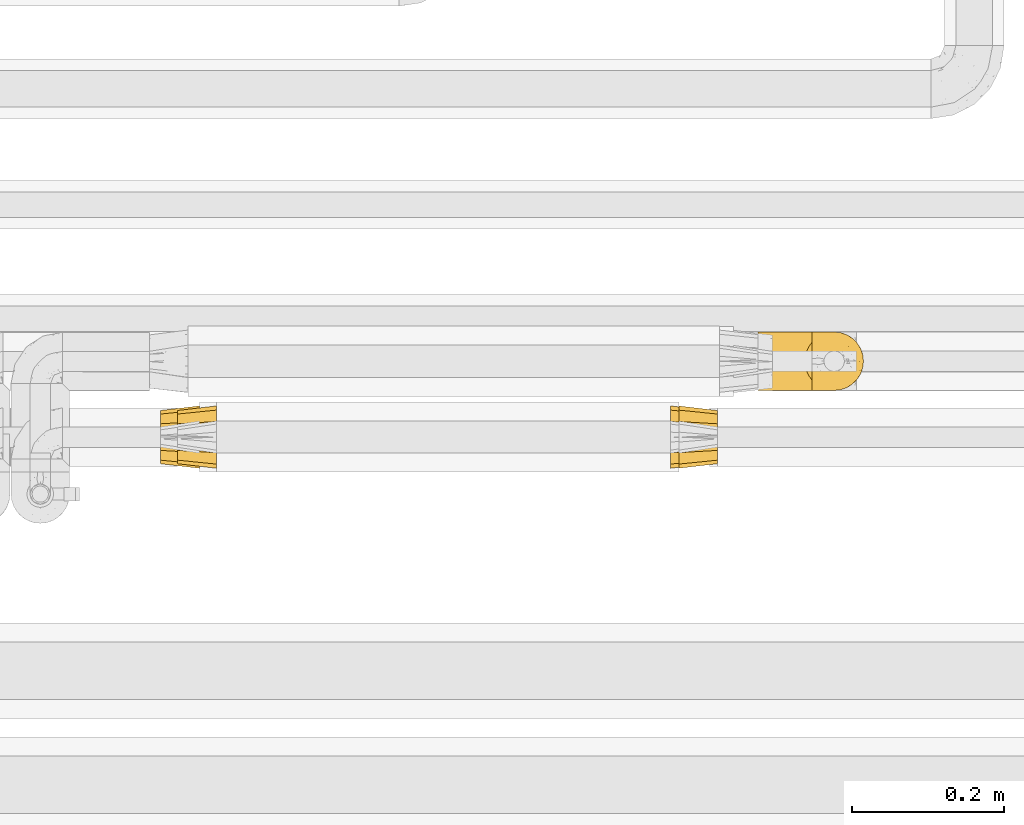
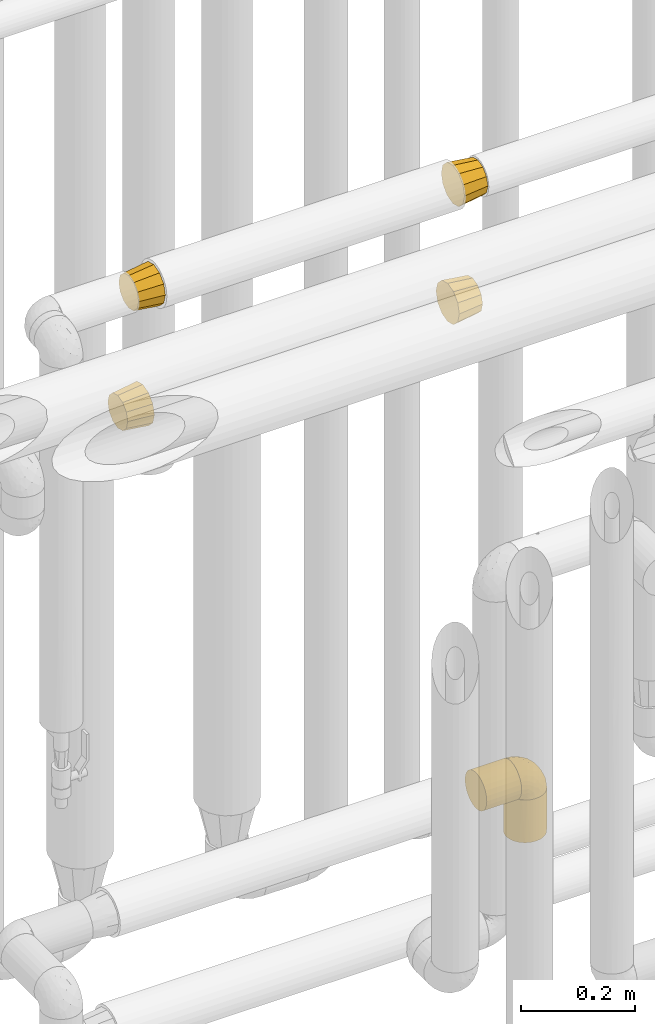
# One storey, part 471 of 827: 7 coverings.
"""IFC2X3 building model written with IfcOpenShell, lengths in millimetres."""

from ifc_helpers import new_model, entity, si_unit, converted_unit, derived_unit, direction, frame, origin, place, context, subcontext, project, spatial, faceted_brep, element, save


model = new_model("IFC2X3")

# Units and contexts
model_context = context("Model", 3, precision=0.01, world=origin(), true_north=direction((6.12303176911189e-17, 1.0)))
body_context = subcontext(model_context, "Body", "Model", "MODEL_VIEW")
ifc_project = project(units=[si_unit("LENGTHUNIT", "METRE", prefix="MILLI"), si_unit("AREAUNIT", "SQUARE_METRE"), si_unit("VOLUMEUNIT", "CUBIC_METRE"), converted_unit("PLANEANGLEUNIT", "DEGREE", entity("IfcRatioMeasure", 0.0174532925199433), si_unit("PLANEANGLEUNIT", "RADIAN"), dimensions=[0, 0, 0, 0, 0, 0, 0]), si_unit("MASSUNIT", "GRAM", prefix="KILO"), derived_unit("MASSDENSITYUNIT", [(si_unit("MASSUNIT", "GRAM", prefix="KILO"), 1), (si_unit("LENGTHUNIT", "METRE"), -3)]), derived_unit("MOMENTOFINERTIAUNIT", [(si_unit("LENGTHUNIT", "METRE"), 4)]), si_unit("TIMEUNIT", "SECOND"), si_unit("FREQUENCYUNIT", "HERTZ"), si_unit("THERMODYNAMICTEMPERATUREUNIT", "DEGREE_CELSIUS"), derived_unit("THERMALTRANSMITTANCEUNIT", [(si_unit("MASSUNIT", "GRAM", prefix="KILO"), 1), (si_unit("THERMODYNAMICTEMPERATUREUNIT", "KELVIN"), -1), (si_unit("TIMEUNIT", "SECOND"), -3)]), derived_unit("VOLUMETRICFLOWRATEUNIT", [(si_unit("LENGTHUNIT", "METRE"), 3), (si_unit("TIMEUNIT", "SECOND"), -1)]), derived_unit("MASSFLOWRATEUNIT", [(si_unit("MASSUNIT", "GRAM", prefix="KILO"), 1), (si_unit("TIMEUNIT", "SECOND"), -1)]), derived_unit("ROTATIONALFREQUENCYUNIT", [(si_unit("TIMEUNIT", "SECOND"), -1)]), si_unit("ELECTRICCURRENTUNIT", "AMPERE"), si_unit("ELECTRICVOLTAGEUNIT", "VOLT"), si_unit("POWERUNIT", "WATT"), si_unit("FORCEUNIT", "NEWTON", prefix="KILO"), si_unit("ILLUMINANCEUNIT", "LUX"), si_unit("LUMINOUSFLUXUNIT", "LUMEN"), si_unit("LUMINOUSINTENSITYUNIT", "CANDELA"), derived_unit("USERDEFINED", [(si_unit("MASSUNIT", "GRAM", prefix="KILO"), -1), (si_unit("LENGTHUNIT", "METRE"), -2), (si_unit("TIMEUNIT", "SECOND"), 3), (si_unit("LUMINOUSFLUXUNIT", "LUMEN"), 1)]), derived_unit("LINEARVELOCITYUNIT", [(si_unit("LENGTHUNIT", "METRE"), 1), (si_unit("TIMEUNIT", "SECOND"), -1)]), si_unit("PRESSUREUNIT", "PASCAL"), derived_unit("USERDEFINED", [(si_unit("LENGTHUNIT", "METRE"), -2), (si_unit("MASSUNIT", "GRAM", prefix="KILO"), 1), (si_unit("TIMEUNIT", "SECOND"), -2)]), derived_unit("LINEARFORCEUNIT", [(si_unit("MASSUNIT", "GRAM", prefix="KILO"), 1), (si_unit("LENGTHUNIT", "METRE"), 1), (si_unit("TIMEUNIT", "SECOND"), -2), (si_unit("LENGTHUNIT", "METRE"), -1)]), derived_unit("PLANARFORCEUNIT", [(si_unit("MASSUNIT", "GRAM", prefix="KILO"), 1), (si_unit("LENGTHUNIT", "METRE"), 1), (si_unit("TIMEUNIT", "SECOND"), -2), (si_unit("LENGTHUNIT", "METRE"), -2)])], contexts=[model_context])

# Site, building, storey
site_placement = place(None, origin())
site = spatial("IfcSite", under=ifc_project, at=site_placement, CompositionType="ELEMENT")
building_placement = place(site_placement, origin())
building = spatial("IfcBuilding", under=site, at=building_placement, CompositionType="ELEMENT")
storey_placement = place(building_placement, frame((0.0, 0.0, 28200.0)))
storey = spatial("IfcBuildingStorey", under=building, at=storey_placement, Name="08", CompositionType="ELEMENT", Elevation=28200.0)

# Coverings
covering_1_placement = place(storey_placement, frame((58750.1, 16337.24, 2607.4)))
element("IfcCovering", 1, at=covering_1_placement, inside=storey, Name=":ADSK_", ObjectType=":ADSK_", PredefinedType="INSULATION", context=body_context, shape_type="Brep", body=[
    faceted_brep([(51.0, 14.59, 70.6), (51.0, 7.09, 63.1), (51.0, 5.43, 56.92), (51.0, 3.51, 49.76), (51.0, 1.6, 42.6), (51.0, 3.51, 35.43), (51.0, 5.43, 28.27), (51.0, 7.09, 22.1), (51.0, 14.59, 14.59), (51.0, 22.1, 7.09), (51.0, 28.27, 5.43), (51.0, 35.43, 3.51), (51.0, 42.6, 1.6), (51.0, 49.76, 3.51), (51.0, 56.92, 5.43), (51.0, 63.1, 7.09), (51.0, 70.6, 14.59), (51.0, 78.1, 22.1), (51.0, 79.76, 28.27), (51.0, 81.68, 35.43), (51.0, 83.6, 42.6), (51.0, 81.68, 49.76), (51.0, 79.76, 56.92), (51.0, 78.1, 63.1), (51.0, 70.6, 70.6), (51.0, 63.1, 78.1), (51.0, 56.92, 79.76), (51.0, 49.76, 81.68), (51.0, 42.6, 83.6), (51.0, 35.43, 81.68), (51.0, 28.27, 79.76), (51.0, 22.1, 78.1), (0.0, 60.1, 72.91), (0.0, 66.5, 66.5), (0.0, 72.91, 60.1), (0.0, 75.25, 51.35), (0.0, 77.6, 42.6), (0.0, 75.25, 33.85), (0.0, 72.91, 25.1), (0.0, 66.5, 18.69), (0.0, 60.1, 12.28), (0.0, 51.35, 9.94), (0.0, 42.6, 7.6), (0.0, 33.85, 9.94), (0.0, 25.1, 12.28), (0.0, 18.69, 18.69), (0.0, 12.28, 25.1), (0.0, 9.94, 33.85), (0.0, 7.6, 42.6), (0.0, 9.94, 51.35), (0.0, 12.28, 60.1), (0.0, 18.69, 66.5), (0.0, 25.1, 72.91), (0.0, 33.85, 75.25), (0.0, 42.6, 77.6), (0.0, 51.35, 75.25)], [[[0, 1, 2, 3, 4, 5, 6, 7, 8, 9, 10, 11, 12, 13, 14, 15, 16, 17, 18, 19, 20, 21, 22, 23, 24, 25, 26, 27, 28, 29, 30, 31]], [[32, 33, 34, 35, 36, 37, 38, 39, 40, 41, 42, 43, 44, 45, 46, 47, 48, 49, 50, 51, 52, 53, 54, 55]], [[46, 7, 6, 5, 4, 48, 47]], [[8, 7, 46, 45, 44, 9]], [[11, 10, 9, 44, 43, 42, 12]], [[40, 15, 14, 13, 12, 42, 41]], [[16, 15, 40, 39, 38, 17]], [[19, 18, 17, 38, 37, 36, 20]], [[34, 23, 22, 21, 20, 36, 35]], [[24, 23, 34, 33, 32, 25]], [[27, 26, 25, 32, 55, 54, 28]], [[52, 31, 30, 29, 28, 54, 53]], [[0, 31, 52, 51, 50, 1]], [[3, 2, 1, 50, 49, 48, 4]]]),
])
covering_2_placement = place(storey_placement, frame((59409.44, 16337.24, 2607.4)))
element("IfcCovering", 2, at=covering_2_placement, inside=storey, Name=":ADSK_", ObjectType=":ADSK_", PredefinedType="INSULATION", context=body_context, shape_type="Brep", body=[
    faceted_brep([(51.0, 9.94, 51.35), (51.0, 7.6, 42.6), (51.0, 9.94, 33.85), (51.0, 12.28, 25.1), (51.0, 18.69, 18.69), (51.0, 25.1, 12.28), (51.0, 33.85, 9.94), (51.0, 42.6, 7.6), (51.0, 51.35, 9.94), (51.0, 60.1, 12.28), (51.0, 66.5, 18.69), (51.0, 72.91, 25.1), (51.0, 75.25, 33.85), (51.0, 77.6, 42.6), (51.0, 75.25, 51.35), (51.0, 72.91, 60.1), (51.0, 66.5, 66.5), (51.0, 60.1, 72.91), (51.0, 51.35, 75.25), (51.0, 42.6, 77.6), (51.0, 33.85, 75.25), (51.0, 25.1, 72.91), (51.0, 18.69, 66.5), (51.0, 12.28, 60.1), (0.0, 70.6, 70.6), (0.0, 78.1, 63.1), (0.0, 79.76, 56.92), (0.0, 81.68, 49.76), (0.0, 83.6, 42.6), (0.0, 81.68, 35.43), (0.0, 79.76, 28.27), (0.0, 78.1, 22.1), (0.0, 70.6, 14.59), (0.0, 63.1, 7.09), (0.0, 56.92, 5.43), (0.0, 49.76, 3.51), (0.0, 42.6, 1.6), (0.0, 35.43, 3.51), (0.0, 28.27, 5.43), (0.0, 22.1, 7.09), (0.0, 14.59, 14.59), (0.0, 7.09, 22.1), (0.0, 5.43, 28.27), (0.0, 3.51, 35.43), (0.0, 1.6, 42.6), (0.0, 3.51, 49.76), (0.0, 5.43, 56.92), (0.0, 7.09, 63.1), (0.0, 14.59, 70.6), (0.0, 22.1, 78.1), (0.0, 28.27, 79.76), (0.0, 35.43, 81.68), (0.0, 42.6, 83.6), (0.0, 49.76, 81.68), (0.0, 56.92, 79.76), (0.0, 63.1, 78.1)], [[[0, 1, 2, 3, 4, 5, 6, 7, 8, 9, 10, 11, 12, 13, 14, 15, 16, 17, 18, 19, 20, 21, 22, 23]], [[24, 25, 26, 27, 28, 29, 30, 31, 32, 33, 34, 35, 36, 37, 38, 39, 40, 41, 42, 43, 44, 45, 46, 47, 48, 49, 50, 51, 52, 53, 54, 55]], [[5, 39, 38, 37, 36, 7, 6]], [[41, 40, 39, 5, 4, 3]], [[43, 42, 41, 3, 2, 1, 44]], [[11, 31, 30, 29, 28, 13, 12]], [[33, 32, 31, 11, 10, 9]], [[35, 34, 33, 9, 8, 7, 36]], [[17, 55, 54, 53, 52, 19, 18]], [[25, 24, 55, 17, 16, 15]], [[27, 26, 25, 15, 14, 13, 28]], [[23, 47, 46, 45, 44, 1, 0]], [[49, 48, 47, 23, 22, 21]], [[51, 50, 49, 21, 20, 19, 52]]]),
])
covering_3_placement = place(storey_placement, frame((59398.77, 16337.24, 2357.4)))
element("IfcCovering", 3, at=covering_3_placement, inside=storey, Name=":ADSK_", ObjectType=":ADSK_", PredefinedType="INSULATION", context=body_context, shape_type="Brep", body=[
    faceted_brep([(0.09, 70.6, 70.6), (0.08, 78.1, 63.1), (0.07, 79.76, 56.92), (0.06, 81.68, 49.76), (0.05, 83.6, 42.6), (0.04, 81.68, 35.43), (0.03, 79.76, 28.27), (0.03, 78.1, 22.1), (0.02, 70.6, 14.59), (0.01, 63.1, 7.09), (0.0, 56.92, 5.43), (0.0, 49.76, 3.51), (0.0, 42.6, 1.6), (0.0, 35.43, 3.51), (0.0, 28.27, 5.43), (0.01, 22.1, 7.09), (0.02, 14.59, 14.59), (0.03, 7.09, 22.1), (0.03, 5.43, 28.27), (0.04, 3.51, 35.43), (0.05, 1.6, 42.6), (0.06, 3.51, 49.76), (0.07, 5.43, 56.92), (0.08, 7.09, 63.1), (0.09, 14.59, 70.6), (0.1, 22.1, 78.1), (0.1, 28.27, 79.76), (0.1, 35.43, 81.68), (0.1, 42.6, 83.6), (0.1, 49.76, 81.68), (0.1, 56.92, 79.76), (0.1, 63.1, 78.1), (51.09, 25.1, 72.84), (51.08, 18.69, 66.44), (51.07, 12.28, 60.03), (51.06, 9.94, 51.28), (51.05, 7.6, 42.53), (51.04, 9.94, 33.78), (51.03, 12.28, 25.03), (51.02, 18.69, 18.63), (51.01, 25.1, 12.22), (51.01, 33.85, 9.88), (51.01, 42.6, 7.53), (51.01, 51.35, 9.88), (51.01, 60.1, 12.22), (51.02, 66.5, 18.63), (51.03, 72.91, 25.03), (51.04, 75.25, 33.78), (51.05, 77.6, 42.53), (51.06, 75.25, 51.28), (51.07, 72.91, 60.03), (51.08, 66.5, 66.44), (51.09, 60.1, 72.84), (51.09, 51.35, 75.19), (51.1, 42.6, 77.53), (51.09, 33.85, 75.19)], [[[0, 1, 2, 3, 4, 5, 6, 7, 8, 9, 10, 11, 12, 13, 14, 15, 16, 17, 18, 19, 20, 21, 22, 23, 24, 25, 26, 27, 28, 29, 30, 31]], [[32, 33, 34, 35, 36, 37, 38, 39, 40, 41, 42, 43, 44, 45, 46, 47, 48, 49, 50, 51, 52, 53, 54, 55]], [[46, 7, 6, 5, 4, 48, 47]], [[8, 7, 46, 45, 44, 9]], [[11, 10, 9, 44, 43, 42, 12]], [[40, 15, 14, 13, 12, 42, 41]], [[16, 15, 40, 39, 38, 17]], [[19, 18, 17, 38, 37, 36, 20]], [[34, 23, 22, 21, 20, 36, 35]], [[24, 23, 34, 33, 32, 25]], [[27, 26, 25, 32, 55, 54, 28]], [[52, 31, 30, 29, 28, 54, 53]], [[0, 31, 52, 51, 50, 1]], [[3, 2, 1, 50, 49, 48, 4]]]),
])
covering_4_placement = place(storey_placement, frame((58727.82, 16337.24, 2357.4)))
element("IfcCovering", 4, at=covering_4_placement, inside=storey, Name=":ADSK_", ObjectType=":ADSK_", PredefinedType="INSULATION", context=body_context, shape_type="Brep", body=[
    faceted_brep([(0.0, 75.25, 51.35), (0.0, 77.6, 42.6), (0.0, 75.25, 33.85), (0.0, 72.91, 25.1), (0.0, 66.5, 18.69), (0.0, 60.1, 12.28), (0.0, 51.35, 9.94), (0.0, 42.6, 7.6), (0.0, 33.85, 9.94), (0.0, 25.1, 12.28), (0.0, 18.69, 18.69), (0.0, 12.28, 25.1), (0.0, 9.94, 33.85), (0.0, 7.6, 42.6), (0.0, 9.94, 51.35), (0.0, 12.28, 60.1), (0.0, 18.69, 66.5), (0.0, 25.1, 72.91), (0.0, 33.85, 75.25), (0.0, 42.6, 77.6), (0.0, 51.35, 75.25), (0.0, 60.1, 72.91), (0.0, 66.5, 66.5), (0.0, 72.91, 60.1), (51.0, 14.59, 70.6), (51.0, 7.09, 63.1), (51.0, 5.43, 56.92), (51.0, 3.51, 49.76), (51.0, 1.6, 42.6), (51.0, 3.51, 35.43), (51.0, 5.43, 28.27), (51.0, 7.09, 22.1), (51.0, 14.59, 14.59), (51.0, 22.1, 7.09), (51.0, 28.27, 5.43), (51.0, 35.43, 3.51), (51.0, 42.6, 1.6), (51.0, 49.76, 3.51), (51.0, 56.92, 5.43), (51.0, 63.1, 7.09), (51.0, 70.6, 14.59), (51.0, 78.1, 22.1), (51.0, 79.76, 28.27), (51.0, 81.68, 35.43), (51.0, 83.6, 42.6), (51.0, 81.68, 49.76), (51.0, 79.76, 56.92), (51.0, 78.1, 63.1), (51.0, 70.6, 70.6), (51.0, 63.1, 78.1), (51.0, 56.92, 79.76), (51.0, 49.76, 81.68), (51.0, 42.6, 83.6), (51.0, 35.43, 81.68), (51.0, 28.27, 79.76), (51.0, 22.1, 78.1)], [[[0, 1, 2, 3, 4, 5, 6, 7, 8, 9, 10, 11, 12, 13, 14, 15, 16, 17, 18, 19, 20, 21, 22, 23]], [[24, 25, 26, 27, 28, 29, 30, 31, 32, 33, 34, 35, 36, 37, 38, 39, 40, 41, 42, 43, 44, 45, 46, 47, 48, 49, 50, 51, 52, 53, 54, 55]], [[5, 39, 38, 37, 36, 7, 6]], [[41, 40, 39, 5, 4, 3]], [[43, 42, 41, 3, 2, 1, 44]], [[11, 31, 30, 29, 28, 13, 12]], [[33, 32, 31, 11, 10, 9]], [[35, 34, 33, 9, 8, 7, 36]], [[17, 55, 54, 53, 52, 19, 18]], [[25, 24, 55, 17, 16, 15]], [[27, 26, 25, 15, 14, 13, 28]], [[23, 47, 46, 45, 44, 1, 0]], [[49, 48, 47, 23, 22, 21]], [[51, 50, 49, 21, 20, 19, 52]]]),
])
covering_5_placement = place(storey_placement, frame((59513.86, 16439.66, 1210.0)))
element("IfcCovering", 5, at=covering_5_placement, inside=storey, Name=":ADSK_", ObjectType=":ADSK_", PredefinedType="INSULATION", context=body_context, shape_type="Brep", body=[
    faceted_brep([(70.9, 77.51, 31.79), (70.9, 78.4, 40.0), (70.9, 77.09, 49.93), (70.9, 73.25, 59.2), (70.9, 67.15, 67.15), (70.9, 59.2, 73.25), (70.9, 49.93, 77.09), (70.9, 40.0, 78.4), (70.9, 30.06, 77.09), (70.9, 20.8, 73.25), (70.9, 12.84, 67.15), (70.9, 6.74, 59.2), (70.9, 2.9, 49.93), (70.9, 1.6, 40.0), (70.9, 2.48, 31.79), (70.9, 5.09, 23.98), (70.9, 9.31, 16.91), (70.9, 14.94, 10.9), (70.9, 65.05, 10.9), (70.9, 70.68, 16.91), (70.9, 74.9, 23.98), (0.0, 59.2, 6.74), (0.0, 49.93, 2.9), (0.0, 40.0, 1.6), (0.0, 30.06, 2.9), (0.0, 20.8, 6.74), (0.0, 12.84, 12.84), (0.0, 6.74, 20.8), (0.0, 2.9, 30.06), (0.0, 1.6, 40.0), (0.0, 2.9, 49.93), (0.0, 6.74, 59.2), (0.0, 12.84, 67.15), (0.0, 20.8, 73.25), (0.0, 30.06, 77.09), (0.0, 40.0, 78.4), (0.0, 49.93, 77.09), (0.0, 59.2, 73.25), (0.0, 67.15, 67.15), (0.0, 73.25, 59.2), (0.0, 77.09, 49.93), (0.0, 78.4, 40.0), (0.0, 77.09, 30.06), (0.0, 73.25, 20.8), (0.0, 67.15, 12.84), (64.0, 26.63, 4.0), (62.2, 33.21, 2.2), (61.6, 40.0, 1.6), (66.93, 20.48, 6.92), (62.2, 46.78, 2.2), (64.0, 53.36, 4.0), (66.93, 59.51, 6.92)], [[[0, 1, 2, 3, 4, 5, 6, 7, 8, 9, 10, 11, 12, 13, 14, 15, 16, 17, 18, 19, 20]], [[21, 22, 23, 24, 25, 26, 27, 28, 29, 30, 31, 32, 33, 34, 35, 36, 37, 38, 39, 40, 41, 42, 43, 44]], [[29, 28, 14]], [[27, 26, 16]], [[28, 27, 15]], [[13, 29, 14]], [[16, 15, 27]], [[28, 15, 14]], [[26, 17, 16]], [[45, 25, 24]], [[24, 23, 46]], [[47, 46, 23]], [[48, 17, 25]], [[46, 45, 24]], [[48, 25, 45]], [[25, 17, 26]], [[49, 47, 23]], [[49, 23, 22]], [[50, 22, 21]], [[50, 49, 22]], [[18, 51, 21]], [[50, 21, 51]], [[21, 44, 18]], [[19, 44, 43]], [[20, 43, 42]], [[0, 42, 41]], [[19, 43, 20]], [[20, 42, 0]], [[41, 1, 0]], [[44, 19, 18]], [[2, 1, 41, 40]], [[3, 2, 40, 39]], [[39, 38, 4, 3]], [[6, 5, 37, 36]], [[7, 6, 36, 35]], [[38, 37, 5, 4]], [[8, 7, 35, 34]], [[9, 8, 34, 33]], [[33, 32, 10, 9]], [[12, 11, 31, 30]], [[13, 12, 30, 29]], [[32, 31, 11, 10]], [[49, 50, 51, 18, 17, 48, 45, 46, 47]]]),
])
covering_6_placement = place(storey_placement, frame((59573.87, 16439.66, 1127.5)))
element("IfcCovering", 6, at=covering_6_placement, inside=storey, Name=":ADSK_", ObjectType=":ADSK_", PredefinedType="INSULATION", context=body_context, shape_type="Brep", body=[
    faceted_brep([(73.25, 20.8, 93.4), (77.09, 30.06, 93.4), (78.4, 40.0, 93.4), (77.09, 49.93, 93.4), (73.25, 59.2, 93.4), (67.15, 67.15, 93.4), (59.2, 73.25, 93.4), (49.93, 77.09, 93.4), (40.0, 78.4, 93.4), (31.79, 77.51, 93.4), (23.98, 74.9, 93.4), (16.91, 70.68, 93.4), (10.9, 65.05, 93.4), (10.9, 14.94, 93.4), (16.91, 9.31, 93.4), (23.98, 5.09, 93.4), (31.79, 2.48, 93.4), (40.0, 1.6, 93.4), (49.93, 2.9, 93.4), (59.2, 6.74, 93.4), (67.15, 12.84, 93.4), (69.1, 14.94, 1.6), (63.08, 9.31, 1.6), (56.01, 5.09, 1.6), (48.2, 2.48, 1.6), (40.0, 1.6, 1.6), (30.06, 2.9, 1.6), (20.8, 6.74, 1.6), (12.84, 12.84, 1.6), (6.74, 20.8, 1.6), (2.9, 30.06, 1.6), (1.6, 40.0, 1.6), (2.9, 49.93, 1.6), (6.74, 59.2, 1.6), (12.84, 67.15, 1.6), (20.8, 73.25, 1.6), (30.06, 77.09, 1.6), (40.0, 78.4, 1.6), (48.2, 77.51, 1.6), (56.01, 74.9, 1.6), (63.08, 70.68, 1.6), (69.1, 65.05, 1.6), (2.2, 33.21, 84.7), (1.6, 40.0, 84.1), (4.0, 26.63, 86.5), (6.92, 20.48, 89.42), (73.07, 20.48, 5.57), (76.0, 26.63, 8.5), (77.79, 33.21, 10.29), (78.4, 40.0, 10.9), (77.79, 46.78, 10.29), (76.0, 53.36, 8.5), (73.07, 59.51, 5.57), (4.0, 53.36, 86.5), (2.2, 46.78, 84.7), (6.92, 59.51, 89.42)], [[[0, 1, 2, 3, 4, 5, 6, 7, 8, 9, 10, 11, 12, 13, 14, 15, 16, 17, 18, 19, 20]], [[21, 22, 23, 24, 25, 26, 27, 28, 29, 30, 31, 32, 33, 34, 35, 36, 37, 38, 39, 40, 41]], [[42, 43, 31]], [[42, 31, 30]], [[44, 30, 29]], [[44, 42, 30]], [[13, 45, 29]], [[44, 29, 45]], [[29, 28, 13]], [[14, 28, 27]], [[15, 27, 26]], [[16, 26, 25]], [[14, 27, 15]], [[15, 26, 16]], [[25, 17, 16]], [[28, 14, 13]], [[17, 25, 24]], [[18, 24, 23]], [[19, 23, 22]], [[17, 24, 18]], [[18, 23, 19]], [[22, 20, 19]], [[22, 21, 20]], [[21, 46, 0]], [[47, 48, 1]], [[46, 47, 0]], [[0, 47, 1]], [[2, 1, 48]], [[49, 2, 48]], [[21, 0, 20]], [[50, 51, 3]], [[52, 41, 4]], [[51, 52, 4]], [[49, 50, 2]], [[2, 50, 3]], [[51, 4, 3]], [[41, 5, 4]], [[6, 40, 39]], [[7, 39, 38]], [[8, 38, 37]], [[5, 40, 6]], [[6, 39, 7]], [[38, 8, 7]], [[40, 5, 41]], [[9, 37, 36]], [[10, 36, 35]], [[11, 35, 34]], [[8, 37, 9]], [[9, 36, 10]], [[35, 11, 10]], [[34, 12, 11]], [[53, 33, 32]], [[32, 31, 54]], [[43, 54, 31]], [[55, 12, 33]], [[54, 53, 32]], [[55, 33, 53]], [[33, 12, 34]], [[54, 43, 42, 44, 45, 13, 12, 55, 53]], [[41, 52, 51, 50, 49, 48, 47, 46, 21]]]),
])
covering_7_placement = place(storey_placement, frame((59583.17, 16439.61, 1219.3)))
element("IfcCovering", 7, at=covering_7_placement, inside=storey, Name=":ADSK_", ObjectType=":ADSK_", PredefinedType="INSULATION", context=body_context, shape_type="Brep", body=[
    faceted_brep([(47.38, 74.68, 1.6), (54.67, 70.1, 1.6), (60.76, 64.01, 1.6), (65.34, 56.72, 1.6), (68.18, 48.6, 1.6), (69.15, 40.05, 1.6), (68.18, 31.49, 1.6), (65.33, 23.36, 1.6), (60.75, 16.07, 1.6), (54.66, 9.98, 1.6), (47.37, 5.4, 1.6), (39.25, 2.56, 1.6), (30.7, 1.6, 1.6), (22.59, 2.46, 1.6), (14.86, 5.01, 1.6), (7.84, 9.13, 1.6), (1.85, 14.62, 1.6), (1.85, 16.82, 1.6), (1.85, 18.56, 1.6), (1.85, 20.52, 1.6), (1.85, 22.49, 1.6), (1.85, 24.46, 1.6), (1.85, 26.42, 1.6), (1.85, 28.39, 1.6), (1.85, 30.36, 1.6), (1.85, 32.55, 1.6), (1.85, 34.75, 1.6), (1.85, 36.94, 1.6), (1.85, 39.13, 1.6), (1.85, 41.33, 1.6), (1.85, 43.52, 1.6), (1.85, 45.72, 1.6), (1.85, 47.91, 1.6), (1.85, 50.11, 1.6), (1.85, 52.3, 1.6), (1.85, 54.49, 1.6), (1.85, 56.69, 1.6), (1.85, 58.88, 1.6), (1.85, 61.08, 1.6), (1.85, 63.27, 1.6), (1.85, 65.47, 1.6), (7.85, 70.97, 1.6), (14.88, 75.09, 1.6), (22.61, 77.64, 1.6), (30.7, 78.5, 1.6), (39.26, 77.53, 1.6), (1.6, 14.62, 1.85), (1.6, 9.12, 7.85), (1.6, 5.0, 14.87), (1.6, 2.46, 22.6), (1.6, 1.6, 30.7), (1.6, 2.91, 40.65), (1.6, 6.75, 49.92), (1.6, 12.86, 57.88), (1.6, 20.82, 63.99), (1.6, 30.09, 67.84), (1.6, 40.05, 69.15), (1.6, 50.0, 67.84), (1.6, 59.27, 63.99), (1.6, 67.23, 57.88), (1.6, 73.34, 49.92), (1.6, 77.19, 40.65), (1.6, 78.5, 30.7), (1.6, 77.63, 22.6), (1.6, 75.09, 14.87), (1.6, 70.97, 7.85), (1.6, 65.47, 1.85), (1.6, 63.27, 1.85), (1.6, 62.29, 1.85), (1.6, 60.7, 1.85), (1.6, 59.11, 1.85), (1.6, 57.52, 1.85), (1.6, 55.93, 1.85), (1.6, 54.34, 1.85), (1.6, 52.76, 1.85), (1.6, 51.17, 1.85), (1.6, 49.58, 1.85), (1.6, 47.99, 1.85), (1.6, 46.4, 1.85), (1.6, 44.81, 1.85), (1.6, 43.22, 1.85), (1.6, 41.63, 1.85), (1.6, 40.05, 1.85), (1.6, 38.46, 1.85), (1.6, 36.87, 1.85), (1.6, 35.28, 1.85), (1.6, 33.69, 1.85), (1.6, 32.1, 1.85), (1.6, 30.51, 1.85), (1.6, 28.92, 1.85), (1.6, 27.33, 1.85), (1.6, 25.37, 1.85), (1.6, 23.4, 1.85), (1.6, 21.21, 1.85), (1.6, 19.01, 1.85), (1.6, 16.82, 1.85), (1.78, 42.32, 1.77), (1.77, 44.02, 1.78), (1.78, 47.13, 1.77), (1.77, 48.74, 1.77), (1.79, 23.57, 1.76), (1.78, 25.13, 1.77), (1.76, 61.34, 1.79), (1.77, 22.02, 1.78), (1.77, 29.72, 1.78), (1.76, 56.73, 1.78), (1.77, 55.14, 1.78), (1.77, 37.66, 1.78), (1.8, 64.12, 1.74), (1.76, 28.13, 1.78), (1.77, 26.62, 1.78), (1.78, 31.46, 1.77), (1.77, 16.16, 1.78), (1.77, 39.16, 1.78), (1.76, 50.37, 1.78), (1.77, 17.69, 1.77), (1.78, 19.17, 1.77), (1.77, 62.78, 1.77), (1.77, 58.35, 1.78), (1.77, 45.53, 1.78), (1.78, 59.91, 1.77), (1.77, 65.47, 1.77), (1.8, 65.47, 1.72), (1.82, 65.47, 1.66), (1.77, 14.62, 1.77), (1.72, 14.62, 1.8), (1.66, 14.62, 1.82), (1.76, 20.59, 1.79), (1.77, 32.99, 1.78), (1.76, 34.48, 1.79), (1.77, 51.91, 1.78), (1.66, 65.47, 1.82), (1.72, 65.47, 1.8), (1.78, 53.48, 1.76), (1.82, 14.62, 1.66), (1.8, 14.62, 1.72), (1.77, 40.77, 1.78), (1.78, 35.97, 1.77), (3.72, 7.84, 9.41), (7.41, 3.53, 17.65), (6.13, 8.32, 7.41), (21.47, 1.6, 21.47), (19.34, 2.19, 15.21), (26.8, 1.6, 16.15), (8.87, 1.6, 28.75), (9.2, 4.57, 13.67), (12.79, 3.96, 12.79), (14.62, 2.28, 19.18), (7.34, 1.6, 29.16), (5.33, 7.69, 9.04), (17.64, 3.53, 7.41), (7.7, 8.32, 5.74), (9.41, 7.84, 3.72), (28.75, 1.6, 8.87), (16.15, 1.6, 26.8), (14.14, 4.34, 9.53), (29.16, 1.6, 7.34), (57.02, 29.63, 37.63), (64.92, 27.34, 17.92), (64.0, 40.05, 27.45), (11.92, 2.39, 37.01), (19.16, 2.43, 34.22), (28.65, 9.07, 45.87), (24.62, 16.64, 56.57), (15.19, 9.54, 52.31), (18.36, 4.52, 42.07), (9.2, 4.52, 44.74), (46.98, 7.49, 21.49), (50.24, 7.49, 11.02), (56.1, 12.85, 15.64), (28.97, 2.35, 26.02), (54.46, 22.66, 36.59), (21.34, 32.9, 65.49), (18.4, 25.33, 63.99), (66.44, 40.05, 15.2), (12.07, 16.64, 60.27), (45.49, 19.99, 45.25), (50.57, 16.37, 35.21), (36.04, 3.26, 22.52), (42.07, 3.75, 12.03), (62.12, 19.58, 13.32), (37.37, 7.5, 35.9), (29.39, 4.04, 33.87), (53.59, 13.94, 25.73), (58.06, 19.58, 26.34), (49.27, 28.21, 46.78), (29.63, 24.75, 59.54), (33.21, 31.42, 60.18), (40.1, 26.2, 53.93), (44.08, 33.36, 53.36), (49.36, 40.05, 49.36), (56.68, 40.05, 38.4), (15.2, 40.05, 66.44), (35.57, 16.14, 50.09), (41.7, 12.85, 41.08), (46.4, 10.47, 31.14), (41.41, 6.49, 28.19), (27.45, 40.05, 64.0), (38.4, 40.05, 56.68), (12.99, 75.57, 43.9), (21.33, 47.37, 65.46), (42.89, 52.91, 52.22), (57.04, 50.46, 37.61), (56.11, 67.23, 15.64), (62.13, 60.5, 13.31), (21.89, 70.55, 50.02), (16.62, 63.45, 59.28), (32.9, 62.61, 53.05), (46.99, 72.6, 21.48), (50.25, 72.6, 11.01), (42.08, 76.34, 12.03), (49.91, 59.34, 41.02), (15.6, 77.76, 35.39), (16.15, 78.5, 26.8), (8.87, 78.5, 28.75), (29.16, 78.5, 7.34), (13.16, 53.16, 65.81), (10.83, 70.55, 53.28), (33.8, 48.88, 59.8), (25.02, 54.76, 61.82), (64.92, 52.74, 17.91), (32.83, 71.93, 41.4), (20.56, 75.79, 40.48), (58.07, 60.5, 26.34), (21.46, 77.86, 31.68), (28.1, 77.64, 27.68), (26.8, 78.5, 16.15), (21.47, 78.5, 21.47), (51.29, 67.23, 28.05), (36.04, 76.82, 22.54), (28.75, 78.5, 8.87), (8.45, 77.8, 37.3), (41.73, 67.23, 41.07), (39.27, 73.2, 32.24), (33.56, 67.66, 47.4), (27.29, 75.99, 35.77), (7.41, 76.57, 17.65), (3.51, 73.21, 11.06), (4.68, 71.93, 8.55), (5.52, 71.07, 6.63), (8.75, 75.09, 12.77), (12.79, 76.13, 12.79), (17.65, 76.57, 7.41), (13.9, 77.69, 18.97), (9.42, 72.26, 3.72), (7.68, 71.77, 5.76), (19.33, 77.9, 15.21), (14.13, 75.75, 9.52)], [[[0, 1, 2, 3, 4, 5, 6, 7, 8, 9, 10, 11, 12, 13, 14, 15, 16, 17, 18, 19, 20, 21, 22, 23, 24, 25, 26, 27, 28, 29, 30, 31, 32, 33, 34, 35, 36, 37, 38, 39, 40, 41, 42, 43, 44, 45]], [[46, 47, 48, 49, 50, 51, 52, 53, 54, 55, 56, 57, 58, 59, 60, 61, 62, 63, 64, 65, 66, 67, 68, 69, 70, 71, 72, 73, 74, 75, 76, 77, 78, 79, 80, 81, 82, 83, 84, 85, 86, 87, 88, 89, 90, 91, 92, 93, 94, 95]], [[96, 97, 30]], [[98, 77, 99]], [[100, 101, 21]], [[69, 68, 102]], [[20, 19, 103]], [[24, 23, 104]], [[20, 103, 100]], [[72, 105, 106]], [[84, 83, 107]], [[89, 88, 104]], [[108, 67, 66]], [[109, 110, 90]], [[111, 25, 24]], [[112, 17, 16]], [[82, 113, 83]], [[109, 23, 22]], [[114, 76, 75]], [[105, 36, 106]], [[104, 111, 24]], [[18, 115, 116]], [[97, 96, 80]], [[67, 108, 117]], [[105, 71, 118]], [[31, 97, 119]], [[102, 120, 69]], [[108, 121, 122, 123, 40]], [[112, 95, 115]], [[17, 115, 18]], [[94, 116, 115]], [[117, 68, 67]], [[38, 117, 39]], [[112, 124, 125, 126, 46]], [[17, 112, 115]], [[70, 120, 118]], [[39, 117, 108]], [[120, 38, 37]], [[120, 37, 118]], [[120, 70, 69]], [[116, 94, 127]], [[128, 86, 129]], [[117, 38, 102]], [[74, 130, 75]], [[99, 33, 32]], [[115, 95, 94]], [[39, 108, 40]], [[108, 66, 131, 132, 121]], [[105, 72, 71]], [[118, 37, 36]], [[71, 70, 118]], [[35, 106, 36]], [[36, 105, 118]], [[35, 133, 106]], [[74, 73, 133]], [[106, 133, 73]], [[99, 114, 33]], [[133, 35, 34]], [[73, 72, 106]], [[95, 112, 46]], [[112, 16, 134, 135, 124]], [[130, 114, 75]], [[99, 76, 114]], [[114, 130, 33]], [[34, 33, 130]], [[78, 77, 98]], [[98, 119, 78]], [[130, 133, 34]], [[133, 130, 74]], [[79, 97, 80]], [[98, 99, 32]], [[98, 32, 31]], [[77, 76, 99]], [[97, 79, 119]], [[136, 96, 29]], [[30, 97, 31]], [[136, 29, 28]], [[81, 80, 96]], [[29, 96, 30]], [[31, 119, 98]], [[119, 79, 78]], [[96, 136, 81]], [[82, 81, 136]], [[113, 107, 83]], [[84, 107, 137]], [[107, 27, 137]], [[113, 28, 107]], [[27, 107, 28]], [[85, 84, 137]], [[137, 27, 26]], [[113, 136, 28]], [[136, 113, 82]], [[109, 89, 104]], [[86, 85, 129]], [[89, 109, 90]], [[111, 87, 128]], [[26, 129, 137]], [[88, 111, 104]], [[25, 111, 128]], [[22, 110, 109]], [[23, 109, 104]], [[110, 91, 90]], [[100, 92, 101]], [[110, 22, 101]], [[91, 110, 101]], [[116, 19, 18]], [[111, 88, 87]], [[127, 103, 19]], [[25, 128, 26]], [[86, 128, 87]], [[128, 129, 26]], [[137, 129, 85]], [[120, 102, 38]], [[117, 102, 68]], [[91, 101, 92]], [[21, 101, 22]], [[93, 92, 103]], [[100, 21, 20]], [[100, 103, 92]], [[127, 93, 103]], [[93, 127, 94]], [[116, 127, 19]], [[126, 138, 47]], [[48, 138, 139]], [[140, 125, 124]], [[141, 142, 143]], [[144, 49, 139]], [[145, 140, 146]], [[48, 139, 49]], [[139, 145, 147]], [[49, 144, 148, 50]], [[126, 125, 149]], [[14, 13, 150]], [[151, 146, 140]], [[149, 140, 145]], [[152, 151, 135]], [[152, 14, 150]], [[16, 15, 134]], [[13, 153, 150]], [[124, 151, 140]], [[141, 147, 142]], [[14, 152, 15]], [[15, 152, 134]], [[47, 46, 126]], [[139, 154, 144]], [[138, 48, 47]], [[125, 140, 149]], [[135, 134, 152]], [[146, 155, 142]], [[145, 146, 147]], [[149, 139, 138]], [[147, 141, 154]], [[147, 146, 142]], [[139, 147, 154]], [[139, 149, 145]], [[149, 138, 126]], [[155, 146, 151]], [[150, 143, 142]], [[152, 155, 151]], [[150, 142, 155]], [[13, 12, 156, 153]], [[153, 143, 150]], [[152, 150, 155]], [[151, 124, 135]], [[157, 158, 159]], [[160, 154, 161]], [[162, 163, 164]], [[165, 166, 160]], [[167, 168, 169]], [[141, 170, 161]], [[156, 12, 11]], [[158, 157, 171]], [[172, 55, 173]], [[158, 6, 174]], [[175, 54, 53]], [[52, 166, 164]], [[52, 164, 53]], [[54, 175, 173]], [[166, 52, 51]], [[176, 177, 171]], [[178, 143, 179]], [[156, 11, 179]], [[8, 7, 180]], [[169, 9, 8]], [[179, 143, 153, 156]], [[179, 11, 10]], [[168, 179, 10]], [[181, 162, 182]], [[179, 167, 178]], [[183, 184, 177]], [[183, 169, 184]], [[176, 171, 185]], [[172, 186, 187]], [[158, 7, 6]], [[159, 158, 174]], [[184, 180, 158]], [[54, 173, 55]], [[180, 169, 8]], [[188, 189, 187]], [[9, 168, 10]], [[186, 188, 187]], [[190, 157, 159, 191]], [[55, 172, 192]], [[176, 193, 194]], [[161, 170, 182]], [[162, 164, 165]], [[175, 164, 163]], [[51, 50, 148]], [[167, 195, 196]], [[178, 182, 170]], [[6, 5, 174]], [[158, 180, 7]], [[169, 180, 184]], [[169, 168, 9]], [[179, 168, 167]], [[182, 162, 165]], [[162, 194, 193]], [[161, 165, 160]], [[195, 181, 196]], [[192, 172, 197]], [[192, 56, 55]], [[189, 190, 198]], [[198, 197, 187]], [[172, 187, 197]], [[185, 189, 188]], [[198, 187, 189]], [[186, 172, 173]], [[173, 163, 186]], [[193, 186, 163]], [[176, 185, 188]], [[185, 157, 190]], [[188, 186, 193]], [[177, 176, 194]], [[188, 193, 176]], [[162, 193, 163]], [[195, 177, 194]], [[171, 177, 184]], [[181, 195, 194]], [[183, 167, 169]], [[162, 181, 194]], [[196, 182, 178]], [[158, 171, 184]], [[171, 157, 185]], [[177, 195, 183]], [[167, 183, 195]], [[182, 196, 181]], [[178, 170, 143]], [[178, 167, 196]], [[164, 175, 53]], [[173, 175, 163]], [[160, 51, 148]], [[164, 166, 165]], [[51, 160, 166]], [[160, 148, 144, 154]], [[141, 161, 154]], [[182, 165, 161]], [[190, 189, 185]], [[143, 170, 141]], [[60, 199, 61]], [[197, 200, 192]], [[201, 190, 202]], [[200, 57, 192]], [[203, 204, 2]], [[205, 206, 207]], [[208, 209, 210]], [[211, 207, 201]], [[212, 213, 214]], [[45, 215, 210]], [[216, 206, 58]], [[45, 44, 215]], [[59, 217, 60]], [[60, 217, 199]], [[0, 45, 210]], [[218, 201, 219]], [[202, 159, 220]], [[205, 221, 222]], [[223, 204, 203]], [[1, 203, 2]], [[57, 200, 216]], [[220, 3, 204]], [[220, 174, 4]], [[1, 0, 209]], [[212, 224, 213]], [[225, 226, 227]], [[228, 223, 203]], [[208, 210, 229]], [[210, 226, 229]], [[3, 220, 4]], [[58, 206, 59]], [[209, 203, 1]], [[202, 220, 223]], [[228, 203, 208]], [[202, 211, 201]], [[3, 2, 204]], [[202, 190, 191, 159]], [[210, 215, 230, 226]], [[199, 212, 231]], [[232, 233, 221]], [[233, 208, 229]], [[207, 206, 219]], [[217, 206, 205]], [[227, 224, 225]], [[233, 232, 228]], [[201, 207, 219]], [[234, 232, 221]], [[218, 219, 200]], [[202, 223, 211]], [[174, 220, 159]], [[174, 5, 4]], [[61, 231, 62]], [[220, 204, 223]], [[210, 209, 0]], [[203, 209, 208]], [[225, 233, 229]], [[224, 227, 213]], [[221, 233, 235]], [[57, 56, 192]], [[198, 218, 197]], [[200, 219, 216]], [[201, 198, 190]], [[197, 218, 200]], [[198, 201, 218]], [[206, 216, 219]], [[58, 57, 216]], [[231, 212, 214]], [[222, 212, 199]], [[228, 211, 223]], [[207, 211, 232]], [[62, 231, 214]], [[199, 231, 61]], [[233, 228, 208]], [[211, 228, 232]], [[222, 221, 235]], [[234, 205, 207]], [[206, 217, 59]], [[199, 217, 205]], [[205, 222, 199]], [[224, 222, 235]], [[222, 224, 212]], [[224, 235, 225]], [[233, 225, 235]], [[226, 225, 229]], [[205, 234, 221]], [[207, 232, 234]], [[63, 214, 236]], [[214, 213, 236]], [[214, 63, 62]], [[237, 236, 238]], [[238, 132, 131]], [[236, 237, 64]], [[239, 240, 241]], [[63, 236, 64]], [[131, 66, 65]], [[237, 131, 65]], [[242, 230, 43]], [[237, 65, 64]], [[239, 121, 132]], [[42, 242, 43]], [[241, 240, 243]], [[41, 123, 244]], [[43, 230, 215, 44]], [[244, 122, 245]], [[227, 246, 243]], [[241, 247, 245]], [[121, 239, 245]], [[41, 40, 123]], [[132, 238, 239]], [[244, 42, 41]], [[131, 237, 238]], [[240, 239, 238]], [[245, 239, 241]], [[247, 241, 246]], [[247, 244, 245]], [[238, 236, 240]], [[243, 236, 213]], [[236, 243, 240]], [[227, 226, 246]], [[243, 213, 227]], [[242, 246, 226]], [[243, 246, 241]], [[246, 242, 247]], [[244, 247, 242]], [[242, 226, 230]], [[42, 244, 242]], [[122, 244, 123]], [[122, 121, 245]]]),
])

save(model, "model.ifc")
